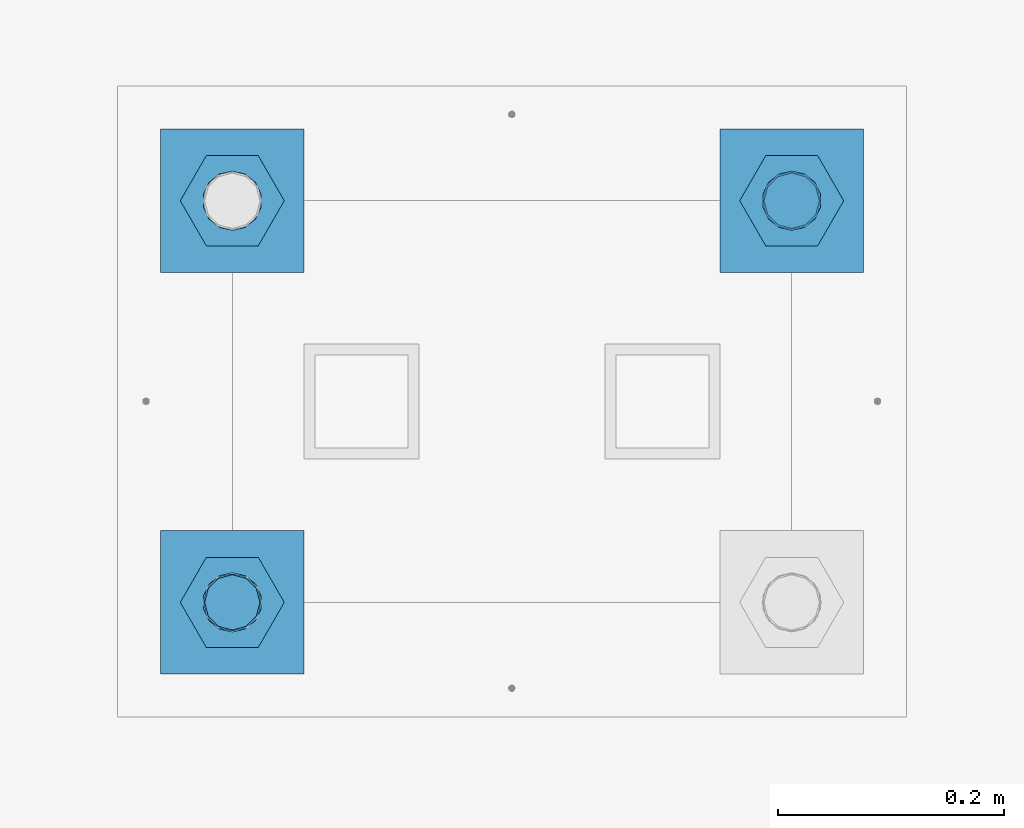
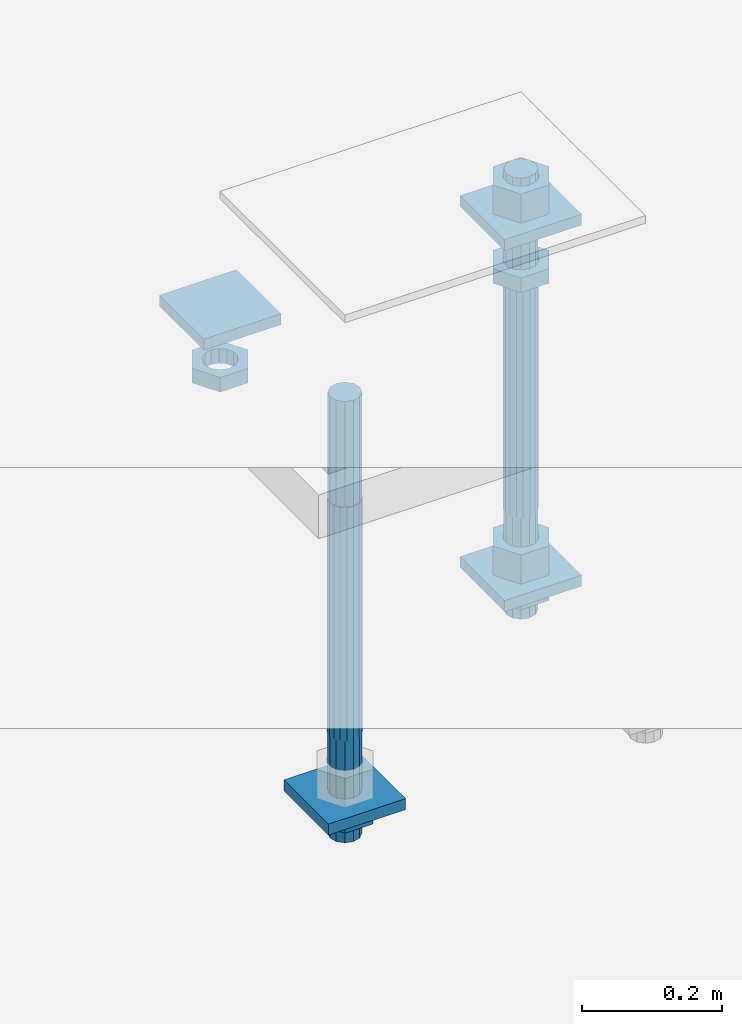
# One storey, part 2771 of 3843: 12 beams, 1 element without a shape of its own.
"""IFC2X3 building model written with IfcOpenShell, lengths in millimetres."""

from ifc_helpers import new_model, si_unit, frame, origin_with_axes, place, context, subcontext, project, spatial, faceted_brep, material, type_object, element, aggregate, save


model = new_model("IFC2X3")

# Units and contexts
model_context = context("Model", 3, precision=1e-05, world=origin_with_axes())
body_context = subcontext(model_context, "Body", "Model", "MODEL_VIEW")
ifc_project = project(units=[si_unit("LENGTHUNIT", "METRE", prefix="MILLI"), si_unit("AREAUNIT", "SQUARE_METRE"), si_unit("VOLUMEUNIT", "CUBIC_METRE"), si_unit("MASSUNIT", "GRAM", prefix="KILO"), si_unit("TIMEUNIT", "SECOND"), si_unit("PLANEANGLEUNIT", "RADIAN"), si_unit("SOLIDANGLEUNIT", "STERADIAN"), si_unit("THERMODYNAMICTEMPERATUREUNIT", "DEGREE_CELSIUS"), si_unit("LUMINOUSINTENSITYUNIT", "LUMEN")], contexts=[model_context])

# Site, building, storey
site_placement = place(None, origin_with_axes())
site = spatial("IfcSite", under=ifc_project, at=site_placement, CompositionType="ELEMENT")
building_placement = place(site_placement, origin_with_axes())
building = spatial("IfcBuilding", under=site, at=building_placement, Name="Undefined", CompositionType="ELEMENT")
storey_placement = place(building_placement, origin_with_axes())
storey = spatial("IfcBuildingStorey", under=building, at=storey_placement, Name="Undefined", CompositionType="ELEMENT", Elevation=0.0)

# Assembly, beams
assembly_placement = place(storey_placement, origin_with_axes())
assembly = element("IfcElementAssembly", 1, at=assembly_placement, inside=storey, Name="TEMPLATE", AssemblyPlace="NOTDEFINED", PredefinedType="RIGID_FRAME")
ifc_material_1 = material(Name="STEEL/A572-50")
beam_type_1 = type_object("IfcBeamType", PredefinedType="NOTDEFINED")
beam_1_placement = place(assembly_placement, frame((119094.25, 52946.2999984741, 29873.575), z_axis=(-1.0, 0.0, 0.0), x_axis=(0.0, -1.0, 0.0)))
beam_1 = element("IfcBeam", 2, at=beam_1_placement, type_object=beam_type_1, material=ifc_material_1, Name="WASHER_PLATE", context=body_context, shape_type="Brep", body=[
    faceted_brep([(0.0, 9.52500000000146, -63.5), (0.0, 9.52500000000146, 63.5), (127.0, 9.52500000000146, 63.5), (127.0, 9.52500000000146, -63.5), (0.0, -9.52500000000146, 63.5), (127.0, -9.52500000000146, 63.5), (0.0, -9.52500000000146, -63.5), (127.0, -9.52500000000146, -63.5)], [[[0, 1, 2, 3]], [[1, 4, 5, 2]], [[4, 6, 7, 5]], [[6, 0, 3, 7]], [[5, 7, 3, 2]], [[6, 4, 1, 0]]]),
])
beam_2_placement = place(assembly_placement, frame((118598.95, 52946.2999984741, 29873.575), z_axis=(-1.0, 0.0, 0.0), x_axis=(0.0, -1.0, 0.0)))
beam_2 = element("IfcBeam", 3, at=beam_2_placement, type_object=beam_type_1, material=ifc_material_1, Name="WASHER_PLATE", context=body_context, shape_type="Brep", body=[
    faceted_brep([(0.0, 9.52500000000146, -63.5), (0.0, 9.52500000000146, 63.5), (127.0, 9.52500000000146, 63.5), (127.0, 9.52500000000146, -63.5), (0.0, -9.52500000000146, 63.5), (127.0, -9.52500000000146, 63.5), (0.0, -9.52500000000146, -63.5), (127.0, -9.52500000000146, -63.5)], [[[0, 1, 2, 3]], [[1, 4, 5, 2]], [[4, 6, 7, 5]], [[6, 0, 3, 7]], [[5, 7, 3, 2]], [[6, 4, 1, 0]]]),
])
beam_3_placement = place(assembly_placement, frame((119094.25, 52946.2999984741, 29244.925), z_axis=(-1.0, 0.0, 0.0), x_axis=(0.0, -1.0, 0.0)))
beam_3 = element("IfcBeam", 4, at=beam_3_placement, type_object=beam_type_1, material=ifc_material_1, Name="WASHER_PLATE", context=body_context, shape_type="Brep", body=[
    faceted_brep([(0.0, 9.52500000000146, -63.5), (0.0, 9.52500000000146, 63.5), (127.0, 9.52500000000146, 63.5), (127.0, 9.52500000000146, -63.5), (0.0, -9.52500000000146, 63.5), (127.0, -9.52500000000146, 63.5), (0.0, -9.52500000000146, -63.5), (127.0, -9.52500000000146, -63.5)], [[[0, 1, 2, 3]], [[1, 4, 5, 2]], [[4, 6, 7, 5]], [[6, 0, 3, 7]], [[5, 7, 3, 2]], [[6, 4, 1, 0]]]),
])
beam_4_placement = place(assembly_placement, frame((118598.95, 52590.6999984741, 29244.925), z_axis=(-1.0, 0.0, 0.0), x_axis=(0.0, -1.0, 0.0)))
beam_4 = element("IfcBeam", 5, at=beam_4_placement, type_object=beam_type_1, material=ifc_material_1, Name="WASHER_PLATE", context=body_context, shape_type="Brep", body=[
    faceted_brep([(0.0, 9.52500000000146, -63.5), (0.0, 9.52500000000146, 63.5), (127.0, 9.52500000000146, 63.5), (127.0, 9.52500000000146, -63.5), (0.0, -9.52500000000146, 63.5), (127.0, -9.52500000000146, 63.5), (0.0, -9.52500000000146, -63.5), (127.0, -9.52500000000146, -63.5)], [[[0, 1, 2, 3]], [[1, 4, 5, 2]], [[4, 6, 7, 5]], [[6, 0, 3, 7]], [[5, 7, 3, 2]], [[6, 4, 1, 0]]]),
])
ifc_material_2 = material(Name="STEEL/A36")
beam_type_2 = type_object("IfcBeamType", Name="2_HALF_NUT", PredefinedType="NOTDEFINED")
beam_5_placement = place(assembly_placement, frame((119094.25, 52882.7999984741, 29787.85), z_axis=(0.0, -1.0, 0.0), x_axis=(0.0, 0.0, -1.0)))
beam_5 = element("IfcBeam", 6, at=beam_5_placement, type_object=beam_type_2, material=ifc_material_2, Name="NUT", ObjectType="2_HALF_NUT", context=body_context, shape_type="Brep", body=[
    faceted_brep([(0.0, -46.0369987487793, 0.0), (0.0, -23.0184993743896, -39.869213104248), (25.4000000000015, -23.0184993743896, -39.869213104248), (25.4000000000015, -46.0369987487793, 0.0), (0.0, 23.0184993743896, -39.869213104248), (25.4000000000015, 23.0184993743896, -39.869213104248), (0.0, 46.0369987487793, 0.0), (25.4000000000015, 46.0369987487793, 0.0), (0.0, 23.0184993743896, 39.869213104248), (25.4000000000015, 23.0184993743896, 39.869213104248), (0.0, -23.0184993743896, 39.869213104248), (25.4000000000015, -23.0184993743896, 39.869213104248), (0.0, 0.0, 26.1940002441406), (0.0, 11.3650617044477, 23.5999013092805), (25.4000000000015, 11.3650617044477, 23.5999013092805), (25.4000000000015, 0.0, 26.1940002441406), (0.0, 20.4791109456419, 16.3316083006721), (25.4000000000015, 20.4791109456419, 16.3316083006721), (0.0, 25.5370200498292, 5.82867859874386), (25.4000000000015, 25.5370200498292, 5.82867859874386), (0.0, 25.5370200498292, -5.82867859874386), (25.4000000000015, 25.5370200498292, -5.82867859874386), (0.0, 20.4791109456419, -16.3316083006721), (25.4000000000015, 20.4791109456419, -16.3316083006721), (0.0, 11.3650617044477, -23.5999013092805), (25.4000000000015, 11.3650617044477, -23.5999013092805), (0.0, 0.0, -26.1940002441406), (25.4000000000015, 0.0, -26.1940002441406), (0.0, -11.3650617044477, -23.5999013092805), (25.4000000000015, -11.3650617044477, -23.5999013092805), (0.0, -20.4791109456419, -16.3316083006721), (25.4000000000015, -20.4791109456419, -16.3316083006721), (0.0, -25.5370200498292, -5.82867859874386), (25.4000000000015, -25.5370200498292, -5.82867859874386), (0.0, -25.5370200498292, 5.82867859874386), (25.4000000000015, -25.5370200498292, 5.82867859874386), (0.0, -20.4791109456419, 16.3316083006721), (25.4000000000015, -20.4791109456419, 16.3316083006721), (0.0, -11.3650617044477, 23.5999013092805), (25.4000000000015, -11.3650617044477, 23.5999013092805)], [[[0, 1, 2, 3]], [[1, 4, 5, 2]], [[4, 6, 7, 5]], [[6, 8, 9, 7]], [[8, 10, 11, 9]], [[10, 0, 3, 11]], [[12, 13, 14, 15]], [[13, 16, 17, 14]], [[16, 18, 19, 17]], [[18, 20, 21, 19]], [[20, 22, 23, 21]], [[22, 24, 25, 23]], [[24, 26, 27, 25]], [[26, 28, 29, 27]], [[28, 30, 31, 29]], [[30, 32, 33, 31]], [[32, 34, 35, 33]], [[34, 36, 37, 35]], [[36, 38, 39, 37]], [[38, 12, 15, 39]], [[5, 7, 9, 11, 3, 2], [17, 19, 21, 23, 25, 27, 29, 31, 33, 35, 37, 39, 15, 14]], [[10, 8, 6, 4, 1, 0], [38, 36, 34, 32, 30, 28, 26, 24, 22, 20, 18, 16, 13, 12]]]),
])
beam_6_placement = place(assembly_placement, frame((119094.25, 52882.7999984741, 29235.4), z_axis=(0.0, -1.0, 0.0), x_axis=(0.0, 0.0, -1.0)))
beam_6 = element("IfcBeam", 7, at=beam_6_placement, type_object=beam_type_2, material=ifc_material_2, Name="NUT", ObjectType="2_HALF_NUT", context=body_context, shape_type="Brep", body=[
    faceted_brep([(0.0, -46.0369987487793, 0.0), (0.0, -23.0184993743896, -39.869213104248), (25.4000000000015, -23.0184993743896, -39.869213104248), (25.4000000000015, -46.0369987487793, 0.0), (0.0, 23.0184993743896, -39.869213104248), (25.4000000000015, 23.0184993743896, -39.869213104248), (0.0, 46.0369987487793, 0.0), (25.4000000000015, 46.0369987487793, 0.0), (0.0, 23.0184993743896, 39.869213104248), (25.4000000000015, 23.0184993743896, 39.869213104248), (0.0, -23.0184993743896, 39.869213104248), (25.4000000000015, -23.0184993743896, 39.869213104248), (0.0, 0.0, 26.1940002441406), (0.0, 11.3650617044477, 23.5999013092805), (25.4000000000015, 11.3650617044477, 23.5999013092805), (25.4000000000015, 0.0, 26.1940002441406), (0.0, 20.4791109456419, 16.3316083006721), (25.4000000000015, 20.4791109456419, 16.3316083006721), (0.0, 25.5370200498292, 5.82867859874386), (25.4000000000015, 25.5370200498292, 5.82867859874386), (0.0, 25.5370200498292, -5.82867859874386), (25.4000000000015, 25.5370200498292, -5.82867859874386), (0.0, 20.4791109456419, -16.3316083006721), (25.4000000000015, 20.4791109456419, -16.3316083006721), (0.0, 11.3650617044477, -23.5999013092805), (25.4000000000015, 11.3650617044477, -23.5999013092805), (0.0, 0.0, -26.1940002441406), (25.4000000000015, 0.0, -26.1940002441406), (0.0, -11.3650617044477, -23.5999013092805), (25.4000000000015, -11.3650617044477, -23.5999013092805), (0.0, -20.4791109456419, -16.3316083006721), (25.4000000000015, -20.4791109456419, -16.3316083006721), (0.0, -25.5370200498292, -5.82867859874386), (25.4000000000015, -25.5370200498292, -5.82867859874386), (0.0, -25.5370200498292, 5.82867859874386), (25.4000000000015, -25.5370200498292, 5.82867859874386), (0.0, -20.4791109456419, 16.3316083006721), (25.4000000000015, -20.4791109456419, 16.3316083006721), (0.0, -11.3650617044477, 23.5999013092805), (25.4000000000015, -11.3650617044477, 23.5999013092805)], [[[0, 1, 2, 3]], [[1, 4, 5, 2]], [[4, 6, 7, 5]], [[6, 8, 9, 7]], [[8, 10, 11, 9]], [[10, 0, 3, 11]], [[12, 13, 14, 15]], [[13, 16, 17, 14]], [[16, 18, 19, 17]], [[18, 20, 21, 19]], [[20, 22, 23, 21]], [[22, 24, 25, 23]], [[24, 26, 27, 25]], [[26, 28, 29, 27]], [[28, 30, 31, 29]], [[30, 32, 33, 31]], [[32, 34, 35, 33]], [[34, 36, 37, 35]], [[36, 38, 39, 37]], [[38, 12, 15, 39]], [[5, 7, 9, 11, 3, 2], [17, 19, 21, 23, 25, 27, 29, 31, 33, 35, 37, 39, 15, 14]], [[10, 8, 6, 4, 1, 0], [38, 36, 34, 32, 30, 28, 26, 24, 22, 20, 18, 16, 13, 12]]]),
])
beam_7_placement = place(assembly_placement, frame((118598.95, 52882.7999984741, 29787.85), z_axis=(0.0, -1.0, 0.0), x_axis=(0.0, 0.0, -1.0)))
beam_7 = element("IfcBeam", 8, at=beam_7_placement, type_object=beam_type_2, material=ifc_material_2, Name="NUT", ObjectType="2_HALF_NUT", context=body_context, shape_type="Brep", body=[
    faceted_brep([(0.0, -46.0369987487793, 0.0), (0.0, -23.0184993743896, -39.869213104248), (25.4000000000015, -23.0184993743896, -39.869213104248), (25.4000000000015, -46.0369987487793, 0.0), (0.0, 23.0184993743896, -39.869213104248), (25.4000000000015, 23.0184993743896, -39.869213104248), (0.0, 46.0369987487793, 0.0), (25.4000000000015, 46.0369987487793, 0.0), (0.0, 23.0184993743896, 39.869213104248), (25.4000000000015, 23.0184993743896, 39.869213104248), (0.0, -23.0184993743896, 39.869213104248), (25.4000000000015, -23.0184993743896, 39.869213104248), (0.0, 0.0, 26.1940002441406), (0.0, 11.3650617044477, 23.5999013092805), (25.4000000000015, 11.3650617044477, 23.5999013092805), (25.4000000000015, 0.0, 26.1940002441406), (0.0, 20.4791109456419, 16.3316083006721), (25.4000000000015, 20.4791109456419, 16.3316083006721), (0.0, 25.5370200498292, 5.82867859874386), (25.4000000000015, 25.5370200498292, 5.82867859874386), (0.0, 25.5370200498292, -5.82867859874386), (25.4000000000015, 25.5370200498292, -5.82867859874386), (0.0, 20.4791109456419, -16.3316083006721), (25.4000000000015, 20.4791109456419, -16.3316083006721), (0.0, 11.3650617044477, -23.5999013092805), (25.4000000000015, 11.3650617044477, -23.5999013092805), (0.0, 0.0, -26.1940002441406), (25.4000000000015, 0.0, -26.1940002441406), (0.0, -11.3650617044477, -23.5999013092805), (25.4000000000015, -11.3650617044477, -23.5999013092805), (0.0, -20.4791109456419, -16.3316083006721), (25.4000000000015, -20.4791109456419, -16.3316083006721), (0.0, -25.5370200498292, -5.82867859874386), (25.4000000000015, -25.5370200498292, -5.82867859874386), (0.0, -25.5370200498292, 5.82867859874386), (25.4000000000015, -25.5370200498292, 5.82867859874386), (0.0, -20.4791109456419, 16.3316083006721), (25.4000000000015, -20.4791109456419, 16.3316083006721), (0.0, -11.3650617044477, 23.5999013092805), (25.4000000000015, -11.3650617044477, 23.5999013092805)], [[[0, 1, 2, 3]], [[1, 4, 5, 2]], [[4, 6, 7, 5]], [[6, 8, 9, 7]], [[8, 10, 11, 9]], [[10, 0, 3, 11]], [[12, 13, 14, 15]], [[13, 16, 17, 14]], [[16, 18, 19, 17]], [[18, 20, 21, 19]], [[20, 22, 23, 21]], [[22, 24, 25, 23]], [[24, 26, 27, 25]], [[26, 28, 29, 27]], [[28, 30, 31, 29]], [[30, 32, 33, 31]], [[32, 34, 35, 33]], [[34, 36, 37, 35]], [[36, 38, 39, 37]], [[38, 12, 15, 39]], [[5, 7, 9, 11, 3, 2], [17, 19, 21, 23, 25, 27, 29, 31, 33, 35, 37, 39, 15, 14]], [[10, 8, 6, 4, 1, 0], [38, 36, 34, 32, 30, 28, 26, 24, 22, 20, 18, 16, 13, 12]]]),
])
beam_8_placement = place(assembly_placement, frame((118598.95, 52527.1999984741, 29235.4), z_axis=(0.0, -1.0, 0.0), x_axis=(0.0, 0.0, -1.0)))
beam_8 = element("IfcBeam", 9, at=beam_8_placement, type_object=beam_type_2, material=ifc_material_2, Name="NUT", ObjectType="2_HALF_NUT", context=body_context, shape_type="Brep", body=[
    faceted_brep([(0.0, -46.0369987487793, 0.0), (0.0, -23.0184993743896, -39.869213104248), (25.4000000000015, -23.0184993743896, -39.869213104248), (25.4000000000015, -46.0369987487793, 0.0), (0.0, 23.0184993743896, -39.869213104248), (25.4000000000015, 23.0184993743896, -39.869213104248), (0.0, 46.0369987487793, 0.0), (25.4000000000015, 46.0369987487793, 0.0), (0.0, 23.0184993743896, 39.869213104248), (25.4000000000015, 23.0184993743896, 39.869213104248), (0.0, -23.0184993743896, 39.869213104248), (25.4000000000015, -23.0184993743896, 39.869213104248), (0.0, 0.0, 26.1940002441406), (0.0, 11.3650617044477, 23.5999013092805), (25.4000000000015, 11.3650617044477, 23.5999013092805), (25.4000000000015, 0.0, 26.1940002441406), (0.0, 20.4791109456419, 16.3316083006721), (25.4000000000015, 20.4791109456419, 16.3316083006721), (0.0, 25.5370200498292, 5.82867859874386), (25.4000000000015, 25.5370200498292, 5.82867859874386), (0.0, 25.5370200498292, -5.82867859874386), (25.4000000000015, 25.5370200498292, -5.82867859874386), (0.0, 20.4791109456419, -16.3316083006721), (25.4000000000015, 20.4791109456419, -16.3316083006721), (0.0, 11.3650617044477, -23.5999013092805), (25.4000000000015, 11.3650617044477, -23.5999013092805), (0.0, 0.0, -26.1940002441406), (25.4000000000015, 0.0, -26.1940002441406), (0.0, -11.3650617044477, -23.5999013092805), (25.4000000000015, -11.3650617044477, -23.5999013092805), (0.0, -20.4791109456419, -16.3316083006721), (25.4000000000015, -20.4791109456419, -16.3316083006721), (0.0, -25.5370200498292, -5.82867859874386), (25.4000000000015, -25.5370200498292, -5.82867859874386), (0.0, -25.5370200498292, 5.82867859874386), (25.4000000000015, -25.5370200498292, 5.82867859874386), (0.0, -20.4791109456419, 16.3316083006721), (25.4000000000015, -20.4791109456419, 16.3316083006721), (0.0, -11.3650617044477, 23.5999013092805), (25.4000000000015, -11.3650617044477, 23.5999013092805)], [[[0, 1, 2, 3]], [[1, 4, 5, 2]], [[4, 6, 7, 5]], [[6, 8, 9, 7]], [[8, 10, 11, 9]], [[10, 0, 3, 11]], [[12, 13, 14, 15]], [[13, 16, 17, 14]], [[16, 18, 19, 17]], [[18, 20, 21, 19]], [[20, 22, 23, 21]], [[22, 24, 25, 23]], [[24, 26, 27, 25]], [[26, 28, 29, 27]], [[28, 30, 31, 29]], [[30, 32, 33, 31]], [[32, 34, 35, 33]], [[34, 36, 37, 35]], [[36, 38, 39, 37]], [[38, 12, 15, 39]], [[5, 7, 9, 11, 3, 2], [17, 19, 21, 23, 25, 27, 29, 31, 33, 35, 37, 39, 15, 14]], [[10, 8, 6, 4, 1, 0], [38, 36, 34, 32, 30, 28, 26, 24, 22, 20, 18, 16, 13, 12]]]),
])
beam_type_3 = type_object("IfcBeamType", Name="2_HEAVY_HEX_NUT", PredefinedType="NOTDEFINED")
beam_9_placement = place(assembly_placement, frame((119094.25, 52882.7999984741, 29933.9), z_axis=(0.0, -1.0, 0.0), x_axis=(0.0, 0.0, -1.0)))
beam_9 = element("IfcBeam", 10, at=beam_9_placement, type_object=beam_type_3, material=ifc_material_2, Name="NUT", ObjectType="2_HEAVY_HEX_NUT", context=body_context, shape_type="Brep", body=[
    faceted_brep([(0.0, -46.0369987487793, 0.0), (0.0, -23.0184993743896, -39.869213104248), (50.7999999999993, -23.0184993743896, -39.869213104248), (50.7999999999993, -46.0369987487793, 0.0), (0.0, 23.0184993743896, -39.869213104248), (50.7999999999993, 23.0184993743896, -39.869213104248), (0.0, 46.0369987487793, 0.0), (50.7999999999993, 46.0369987487793, 0.0), (0.0, 23.0184993743896, 39.869213104248), (50.7999999999993, 23.0184993743896, 39.869213104248), (0.0, -23.0184993743896, 39.869213104248), (50.7999999999993, -23.0184993743896, 39.869213104248), (0.0, 0.0, 26.1940002441406), (0.0, 11.3650617044477, 23.5999013092805), (50.7999999999993, 11.3650617044477, 23.5999013092805), (50.7999999999993, 0.0, 26.1940002441406), (0.0, 20.4791109456419, 16.3316083006721), (50.7999999999993, 20.4791109456419, 16.3316083006721), (0.0, 25.5370200498292, 5.82867859874386), (50.7999999999993, 25.5370200498292, 5.82867859874386), (0.0, 25.5370200498292, -5.82867859874386), (50.7999999999993, 25.5370200498292, -5.82867859874386), (0.0, 20.4791109456419, -16.3316083006721), (50.7999999999993, 20.4791109456419, -16.3316083006721), (0.0, 11.3650617044477, -23.5999013092805), (50.7999999999993, 11.3650617044477, -23.5999013092805), (0.0, 0.0, -26.1940002441406), (50.7999999999993, 0.0, -26.1940002441406), (0.0, -11.3650617044477, -23.5999013092805), (50.7999999999993, -11.3650617044477, -23.5999013092805), (0.0, -20.4791109456419, -16.3316083006721), (50.7999999999993, -20.4791109456419, -16.3316083006721), (0.0, -25.5370200498292, -5.82867859874386), (50.7999999999993, -25.5370200498292, -5.82867859874386), (0.0, -25.5370200498292, 5.82867859874386), (50.7999999999993, -25.5370200498292, 5.82867859874386), (0.0, -20.4791109456419, 16.3316083006721), (50.7999999999993, -20.4791109456419, 16.3316083006721), (0.0, -11.3650617044477, 23.5999013092805), (50.7999999999993, -11.3650617044477, 23.5999013092805)], [[[0, 1, 2, 3]], [[1, 4, 5, 2]], [[4, 6, 7, 5]], [[6, 8, 9, 7]], [[8, 10, 11, 9]], [[10, 0, 3, 11]], [[12, 13, 14, 15]], [[13, 16, 17, 14]], [[16, 18, 19, 17]], [[18, 20, 21, 19]], [[20, 22, 23, 21]], [[22, 24, 25, 23]], [[24, 26, 27, 25]], [[26, 28, 29, 27]], [[28, 30, 31, 29]], [[30, 32, 33, 31]], [[32, 34, 35, 33]], [[34, 36, 37, 35]], [[36, 38, 39, 37]], [[38, 12, 15, 39]], [[5, 7, 9, 11, 3, 2], [17, 19, 21, 23, 25, 27, 29, 31, 33, 35, 37, 39, 15, 14]], [[10, 8, 6, 4, 1, 0], [38, 36, 34, 32, 30, 28, 26, 24, 22, 20, 18, 16, 13, 12]]]),
])
beam_10_placement = place(assembly_placement, frame((119094.25, 52882.7999984741, 29305.25), z_axis=(0.0, -1.0, 0.0), x_axis=(0.0, 0.0, -1.0)))
beam_10 = element("IfcBeam", 11, at=beam_10_placement, type_object=beam_type_3, material=ifc_material_2, Name="NUT", ObjectType="2_HEAVY_HEX_NUT", context=body_context, shape_type="Brep", body=[
    faceted_brep([(0.0, -46.0369987487793, 0.0), (0.0, -23.0184993743896, -39.869213104248), (50.7999999999993, -23.0184993743896, -39.869213104248), (50.7999999999993, -46.0369987487793, 0.0), (0.0, 23.0184993743896, -39.869213104248), (50.7999999999993, 23.0184993743896, -39.869213104248), (0.0, 46.0369987487793, 0.0), (50.7999999999993, 46.0369987487793, 0.0), (0.0, 23.0184993743896, 39.869213104248), (50.7999999999993, 23.0184993743896, 39.869213104248), (0.0, -23.0184993743896, 39.869213104248), (50.7999999999993, -23.0184993743896, 39.869213104248), (0.0, 0.0, 26.1940002441406), (0.0, 11.3650617044477, 23.5999013092805), (50.7999999999993, 11.3650617044477, 23.5999013092805), (50.7999999999993, 0.0, 26.1940002441406), (0.0, 20.4791109456419, 16.3316083006721), (50.7999999999993, 20.4791109456419, 16.3316083006721), (0.0, 25.5370200498292, 5.82867859874386), (50.7999999999993, 25.5370200498292, 5.82867859874386), (0.0, 25.5370200498292, -5.82867859874386), (50.7999999999993, 25.5370200498292, -5.82867859874386), (0.0, 20.4791109456419, -16.3316083006721), (50.7999999999993, 20.4791109456419, -16.3316083006721), (0.0, 11.3650617044477, -23.5999013092805), (50.7999999999993, 11.3650617044477, -23.5999013092805), (0.0, 0.0, -26.1940002441406), (50.7999999999993, 0.0, -26.1940002441406), (0.0, -11.3650617044477, -23.5999013092805), (50.7999999999993, -11.3650617044477, -23.5999013092805), (0.0, -20.4791109456419, -16.3316083006721), (50.7999999999993, -20.4791109456419, -16.3316083006721), (0.0, -25.5370200498292, -5.82867859874386), (50.7999999999993, -25.5370200498292, -5.82867859874386), (0.0, -25.5370200498292, 5.82867859874386), (50.7999999999993, -25.5370200498292, 5.82867859874386), (0.0, -20.4791109456419, 16.3316083006721), (50.7999999999993, -20.4791109456419, 16.3316083006721), (0.0, -11.3650617044477, 23.5999013092805), (50.7999999999993, -11.3650617044477, 23.5999013092805)], [[[0, 1, 2, 3]], [[1, 4, 5, 2]], [[4, 6, 7, 5]], [[6, 8, 9, 7]], [[8, 10, 11, 9]], [[10, 0, 3, 11]], [[12, 13, 14, 15]], [[13, 16, 17, 14]], [[16, 18, 19, 17]], [[18, 20, 21, 19]], [[20, 22, 23, 21]], [[22, 24, 25, 23]], [[24, 26, 27, 25]], [[26, 28, 29, 27]], [[28, 30, 31, 29]], [[30, 32, 33, 31]], [[32, 34, 35, 33]], [[34, 36, 37, 35]], [[36, 38, 39, 37]], [[38, 12, 15, 39]], [[5, 7, 9, 11, 3, 2], [17, 19, 21, 23, 25, 27, 29, 31, 33, 35, 37, 39, 15, 14]], [[10, 8, 6, 4, 1, 0], [38, 36, 34, 32, 30, 28, 26, 24, 22, 20, 18, 16, 13, 12]]]),
])
ifc_material_3 = material()
beam_type_4 = type_object("IfcBeamType", PredefinedType="NOTDEFINED")
beam_11_placement = place(assembly_placement, frame((119094.25, 52882.7999984741, 29762.45), z_axis=(0.0, -1.0, 0.0), x_axis=(0.0, 0.0, -1.0)))
beam_11 = element("IfcBeam", 12, at=beam_11_placement, type_object=beam_type_4, material=ifc_material_3, Name="ANCHOR_ROD", context=body_context, shape_type="Brep", body=[
    faceted_brep([(-184.150000000001, -21.217622392709, 12.25), (-184.150000000001, -12.2499999999854, 21.2176223927163), (-184.150000000001, 1.45519152283669e-11, 24.5), (-184.150000000001, 12.2500000000146, 21.2176223927163), (-184.150000000001, 21.2176223927381, 12.25), (-184.150000000001, 24.5000000000146, 0.0), (-184.150000000001, 21.2176223927381, -12.25), (-184.150000000001, 12.2500000000146, -21.2176223927163), (-184.150000000001, 1.45519152283669e-11, -24.5), (-184.150000000001, -12.2499999999854, -21.2176223927163), (-184.150000000001, -21.217622392709, -12.25), (-184.150000000001, -24.4999999999854, 0.0), (0.0, 24.5000000000146, 0.0), (0.0, 21.2176223927381, -12.25), (0.0, 12.2500000000146, -21.2176223927163), (0.0, 1.45519152283669e-11, -24.5), (0.0, -12.2499999999854, -21.2176223927163), (0.0, -21.217622392709, -12.25), (0.0, -24.4999999999854, 0.0), (0.0, -21.217622392709, 12.25), (0.0, -12.2499999999854, 21.2176223927163), (0.0, 1.45519152283669e-11, 24.5), (0.0, 12.2500000000146, 21.2176223927163), (0.0, 21.2176223927381, 12.25), (0.0, -23.4665401257807, 9.72015918207035), (0.0, -17.9605122421344, 17.9605122421417), (0.0, -9.72015918207762, 23.466540125788), (0.0, 0.0, 25.4000000000015), (0.0, 9.72015918207762, 23.466540125788), (0.0, 17.9605122421344, 17.9605122421417), (0.0, 23.4665401257807, 9.72015918207035), (0.0, 25.3999996185303, 0.0), (0.0, 23.4665401257807, -9.72015918207035), (0.0, 17.9605122421344, -17.9605122421417), (0.0, 9.72015918207762, -23.466540125788), (0.0, 0.0, -25.4000000000015), (0.0, -9.72015918207762, -23.466540125788), (0.0, -17.9605122421344, -17.9605122421417), (0.0, -23.4665401257807, -9.72015918207035), (0.0, -25.3999996185303, 0.0), (406.399999999998, -25.3999999999942, 0.0), (406.399999999998, -23.4665401257807, 9.72015918207035), (406.399999999998, -17.9605122421344, 17.9605122421417), (406.399999999998, -9.72015918207762, 23.466540125788), (406.399999999998, 0.0, 25.4000000000015), (406.399999999998, 9.72015918207762, 23.466540125788), (406.399999999998, 17.9605122421344, 17.9605122421417), (406.399999999998, 23.4665401257807, 9.72015918207035), (406.399999999998, 25.3999999999942, 0.0), (406.399999999998, 23.4665401257807, -9.72015918207035), (406.399999999998, 17.9605122421344, -17.9605122421417), (406.399999999998, 9.72015918207762, -23.466540125788), (406.399999999998, 0.0, -25.4000000000015), (406.399999999998, -9.72015918207762, -23.466540125788), (406.399999999998, -17.9605122421344, -17.9605122421417), (406.399999999998, -23.4665401257807, -9.72015918207035), (406.399999999998, -12.2499999999854, 21.2176223927163), (406.399999999998, 1.45519152283669e-11, 24.5), (406.399999999998, 12.2500000000146, 21.2176223927163), (406.399999999998, 21.2176223927381, 12.25), (406.399999999998, 24.5000000000146, 0.0), (406.399999999998, 21.2176223927381, -12.25), (406.399999999998, 12.2500000000146, -21.2176223927163), (406.399999999998, 1.45519152283669e-11, -24.5), (406.399999999998, -12.2499999999854, -21.2176223927163), (406.399999999998, -21.217622392709, -12.25), (406.399999999998, -24.4999999999854, 0.0), (406.399999999998, -21.217622392709, 12.25), (584.200000000001, -12.2499999999854, -21.2176223927163), (584.200000000001, 1.45519152283669e-11, -24.5), (584.200000000001, 12.2500000000146, -21.2176223927163), (584.200000000001, 21.2176223927381, -12.25), (584.200000000001, 24.5000000000146, 0.0), (584.200000000001, 21.2176223927381, 12.25), (584.200000000001, 12.2500000000146, 21.2176223927163), (584.200000000001, 1.45519152283669e-11, 24.5), (584.200000000001, -12.2499999999854, 21.2176223927163), (584.200000000001, -21.217622392709, 12.25), (584.200000000001, -24.4999999999854, 0.0), (584.200000000001, -21.217622392709, -12.25)], [[[0, 1, 2, 3, 4, 5, 6, 7, 8, 9, 10, 11]], [[6, 5, 12, 13]], [[7, 6, 13, 14]], [[8, 7, 14, 15]], [[9, 8, 15, 16]], [[10, 9, 16, 17]], [[11, 10, 17, 18]], [[0, 11, 18, 19]], [[1, 0, 19, 20]], [[2, 1, 20, 21]], [[3, 2, 21, 22]], [[4, 3, 22, 23]], [[5, 4, 23, 12]], [[24, 25, 26, 27, 28, 29, 30, 31, 32, 33, 34, 35, 36, 37, 38, 39], [22, 21, 20, 19, 18, 17, 16, 15, 14, 13, 12, 23]], [[24, 39, 40, 41]], [[25, 24, 41, 42]], [[26, 25, 42, 43]], [[27, 26, 43, 44]], [[28, 27, 44, 45]], [[29, 28, 45, 46]], [[30, 29, 46, 47]], [[31, 30, 47, 48]], [[32, 31, 48, 49]], [[33, 32, 49, 50]], [[34, 33, 50, 51]], [[35, 34, 51, 52]], [[36, 35, 52, 53]], [[37, 36, 53, 54]], [[38, 37, 54, 55]], [[39, 38, 55, 40]], [[54, 53, 52, 51, 50, 49, 48, 47, 46, 45, 44, 43, 42, 41, 40, 55], [56, 57, 58, 59, 60, 61, 62, 63, 64, 65, 66, 67]], [[68, 69, 70, 71, 72, 73, 74, 75, 76, 77, 78, 79]], [[76, 75, 57, 56]], [[77, 76, 56, 67]], [[78, 77, 67, 66]], [[79, 78, 66, 65]], [[68, 79, 65, 64]], [[69, 68, 64, 63]], [[70, 69, 63, 62]], [[71, 70, 62, 61]], [[72, 71, 61, 60]], [[73, 72, 60, 59]], [[74, 73, 59, 58]], [[75, 74, 58, 57]]]),
])
beam_12_placement = place(assembly_placement, frame((118598.95, 52527.1999984741, 29762.45), z_axis=(0.0, -1.0, 0.0), x_axis=(0.0, 0.0, -1.0)))
beam_12 = element("IfcBeam", 13, at=beam_12_placement, type_object=beam_type_4, material=ifc_material_3, Name="ANCHOR_ROD", context=body_context, shape_type="Brep", body=[
    faceted_brep([(-184.150000000001, -21.217622392709, 12.25), (-184.150000000001, -12.2499999999854, 21.2176223927163), (-184.150000000001, 1.45519152283669e-11, 24.5), (-184.150000000001, 12.2500000000146, 21.2176223927163), (-184.150000000001, 21.2176223927381, 12.25), (-184.150000000001, 24.5000000000146, 0.0), (-184.150000000001, 21.2176223927381, -12.25), (-184.150000000001, 12.2500000000146, -21.2176223927163), (-184.150000000001, 1.45519152283669e-11, -24.5), (-184.150000000001, -12.2499999999854, -21.2176223927163), (-184.150000000001, -21.217622392709, -12.25), (-184.150000000001, -24.4999999999854, 0.0), (0.0, 24.5000000000146, 0.0), (0.0, 21.2176223927381, -12.25), (0.0, 12.2500000000146, -21.2176223927163), (0.0, 1.45519152283669e-11, -24.5), (0.0, -12.2499999999854, -21.2176223927163), (0.0, -21.217622392709, -12.25), (0.0, -24.4999999999854, 0.0), (0.0, -21.217622392709, 12.25), (0.0, -12.2499999999854, 21.2176223927163), (0.0, 1.45519152283669e-11, 24.5), (0.0, 12.2500000000146, 21.2176223927163), (0.0, 21.2176223927381, 12.25), (0.0, -23.4665401257807, 9.72015918207035), (0.0, -17.9605122421344, 17.9605122421417), (0.0, -9.72015918207762, 23.466540125788), (0.0, 0.0, 25.4000000000015), (0.0, 9.72015918207762, 23.466540125788), (0.0, 17.9605122421344, 17.9605122421417), (0.0, 23.4665401257807, 9.72015918207035), (0.0, 25.3999996185303, 0.0), (0.0, 23.4665401257807, -9.72015918207035), (0.0, 17.9605122421344, -17.9605122421417), (0.0, 9.72015918207762, -23.466540125788), (0.0, 0.0, -25.4000000000015), (0.0, -9.72015918207762, -23.466540125788), (0.0, -17.9605122421344, -17.9605122421417), (0.0, -23.4665401257807, -9.72015918207035), (0.0, -25.3999996185303, 0.0), (406.399999999998, -25.3999999999942, 0.0), (406.399999999998, -23.4665401257807, 9.72015918207035), (406.399999999998, -17.9605122421344, 17.9605122421417), (406.399999999998, -9.72015918207762, 23.466540125788), (406.399999999998, 0.0, 25.4000000000015), (406.399999999998, 9.72015918207762, 23.466540125788), (406.399999999998, 17.9605122421344, 17.9605122421417), (406.399999999998, 23.4665401257807, 9.72015918207035), (406.399999999998, 25.3999999999942, 0.0), (406.399999999998, 23.4665401257807, -9.72015918207035), (406.399999999998, 17.9605122421344, -17.9605122421417), (406.399999999998, 9.72015918207762, -23.466540125788), (406.399999999998, 0.0, -25.4000000000015), (406.399999999998, -9.72015918207762, -23.466540125788), (406.399999999998, -17.9605122421344, -17.9605122421417), (406.399999999998, -23.4665401257807, -9.72015918207035), (406.399999999998, -12.2499999999854, 21.2176223927163), (406.399999999998, 1.45519152283669e-11, 24.5), (406.399999999998, 12.2500000000146, 21.2176223927163), (406.399999999998, 21.2176223927381, 12.25), (406.399999999998, 24.5000000000146, 0.0), (406.399999999998, 21.2176223927381, -12.25), (406.399999999998, 12.2500000000146, -21.2176223927163), (406.399999999998, 1.45519152283669e-11, -24.5), (406.399999999998, -12.2499999999854, -21.2176223927163), (406.399999999998, -21.217622392709, -12.25), (406.399999999998, -24.4999999999854, 0.0), (406.399999999998, -21.217622392709, 12.25), (584.200000000001, -12.2499999999854, -21.2176223927163), (584.200000000001, 1.45519152283669e-11, -24.5), (584.200000000001, 12.2500000000146, -21.2176223927163), (584.200000000001, 21.2176223927381, -12.25), (584.200000000001, 24.5000000000146, 0.0), (584.200000000001, 21.2176223927381, 12.25), (584.200000000001, 12.2500000000146, 21.2176223927163), (584.200000000001, 1.45519152283669e-11, 24.5), (584.200000000001, -12.2499999999854, 21.2176223927163), (584.200000000001, -21.217622392709, 12.25), (584.200000000001, -24.4999999999854, 0.0), (584.200000000001, -21.217622392709, -12.25)], [[[0, 1, 2, 3, 4, 5, 6, 7, 8, 9, 10, 11]], [[6, 5, 12, 13]], [[7, 6, 13, 14]], [[8, 7, 14, 15]], [[9, 8, 15, 16]], [[10, 9, 16, 17]], [[11, 10, 17, 18]], [[0, 11, 18, 19]], [[1, 0, 19, 20]], [[2, 1, 20, 21]], [[3, 2, 21, 22]], [[4, 3, 22, 23]], [[5, 4, 23, 12]], [[24, 25, 26, 27, 28, 29, 30, 31, 32, 33, 34, 35, 36, 37, 38, 39], [22, 21, 20, 19, 18, 17, 16, 15, 14, 13, 12, 23]], [[24, 39, 40, 41]], [[25, 24, 41, 42]], [[26, 25, 42, 43]], [[27, 26, 43, 44]], [[28, 27, 44, 45]], [[29, 28, 45, 46]], [[30, 29, 46, 47]], [[31, 30, 47, 48]], [[32, 31, 48, 49]], [[33, 32, 49, 50]], [[34, 33, 50, 51]], [[35, 34, 51, 52]], [[36, 35, 52, 53]], [[37, 36, 53, 54]], [[38, 37, 54, 55]], [[39, 38, 55, 40]], [[54, 53, 52, 51, 50, 49, 48, 47, 46, 45, 44, 43, 42, 41, 40, 55], [56, 57, 58, 59, 60, 61, 62, 63, 64, 65, 66, 67]], [[68, 69, 70, 71, 72, 73, 74, 75, 76, 77, 78, 79]], [[76, 75, 57, 56]], [[77, 76, 56, 67]], [[78, 77, 67, 66]], [[79, 78, 66, 65]], [[68, 79, 65, 64]], [[69, 68, 64, 63]], [[70, 69, 63, 62]], [[71, 70, 62, 61]], [[72, 71, 61, 60]], [[73, 72, 60, 59]], [[74, 73, 59, 58]], [[75, 74, 58, 57]]]),
])
aggregate(assembly, [beam_1, beam_2, beam_5, beam_9, beam_10, beam_6, beam_3, beam_11, beam_7, beam_8, beam_4, beam_12])

save(model, "model.ifc")
